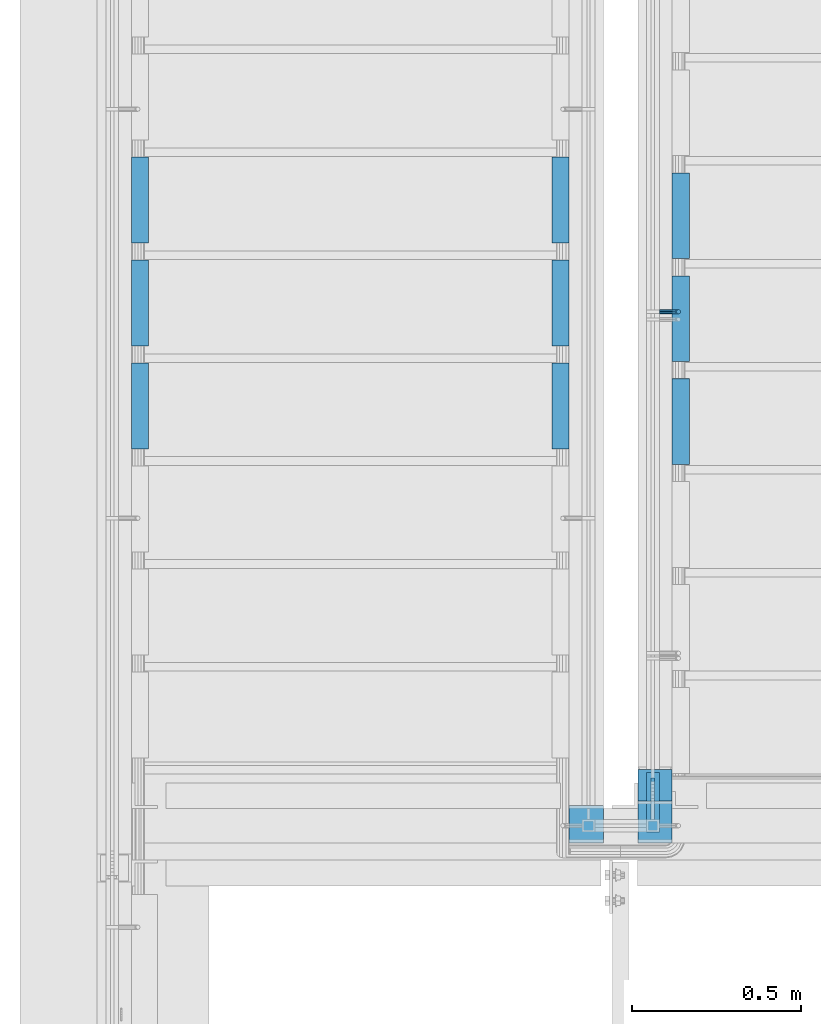
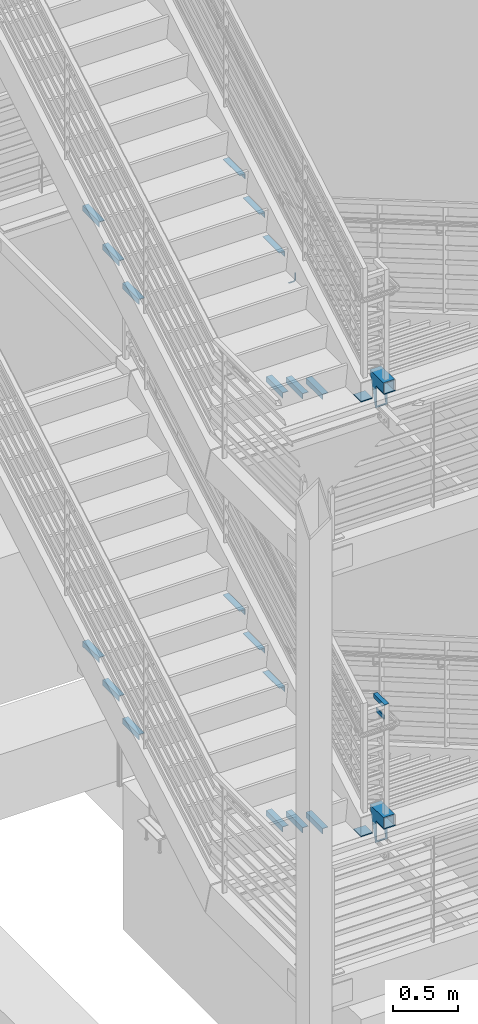
# One storey, part 860 of 1179: 26 beams, 1 member, 6 elements without a shape of their own.
"""IFC2X3 building model written with IfcOpenShell, lengths in millimetres."""

from ifc_helpers import new_model, si_unit, frame, origin_with_axes, place, context, subcontext, project, spatial, faceted_brep, material, type_object, element, aggregate, save


model = new_model("IFC2X3")

# Units and contexts
model_context = context("Model", 3, precision=1e-05, world=origin_with_axes())
body_context = subcontext(model_context, "Body", "Model", "MODEL_VIEW")
ifc_project = project(units=[si_unit("LENGTHUNIT", "METRE", prefix="MILLI"), si_unit("AREAUNIT", "SQUARE_METRE"), si_unit("VOLUMEUNIT", "CUBIC_METRE"), si_unit("MASSUNIT", "GRAM", prefix="KILO"), si_unit("TIMEUNIT", "SECOND"), si_unit("PLANEANGLEUNIT", "RADIAN"), si_unit("SOLIDANGLEUNIT", "STERADIAN"), si_unit("THERMODYNAMICTEMPERATUREUNIT", "DEGREE_CELSIUS"), si_unit("LUMINOUSINTENSITYUNIT", "LUMEN")], contexts=[model_context])

# Site, building, storey
site_placement = place(None, origin_with_axes())
site = spatial("IfcSite", under=ifc_project, at=site_placement, CompositionType="ELEMENT")
building_placement = place(site_placement, origin_with_axes())
building = spatial("IfcBuilding", under=site, at=building_placement, Name="Undefined", CompositionType="ELEMENT")
storey_placement = place(building_placement, origin_with_axes())
storey = spatial("IfcBuildingStorey", under=building, at=storey_placement, Name="Undefined", CompositionType="ELEMENT", Elevation=0.0)

# Assembly, beams
assembly_1_placement = place(storey_placement, origin_with_axes())
assembly_1 = element("IfcElementAssembly", 1, at=assembly_1_placement, inside=storey, Name="STRINGER", AssemblyPlace="NOTDEFINED", PredefinedType="RIGID_FRAME")
ifc_material_1 = material(Name="STEEL/A36")
beam_type_1 = type_object("IfcBeamType", Name="L2X2X3/16", PredefinedType="NOTDEFINED")
beam_1_placement = place(assembly_1_placement, frame((-3174.99999998141, 33462.2643783074, 7178.67500000067), z_axis=(1.0, 0.0, 0.0), x_axis=(0.0, 1.0, 0.0)))
beam_1 = element("IfcBeam", 2, at=beam_1_placement, type_object=beam_type_1, material=ifc_material_1, Name="ANGLE", ObjectType="L2X2X3/16", context=body_context, shape_type="Brep", body=[
    faceted_brep([(0.0, 25.3999999999996, -25.4000000000015), (0.0, 25.3999999999996, 25.4000000000015), (254.0, 25.3999999999996, 25.4000000000001), (254.0, 25.3999999999996, -25.4000000000001), (0.0, 20.6374999999998, 25.4000000000015), (254.0, 20.6374999999998, 25.4000000000001), (0.0, 20.6374999999998, -20.6374999999971), (254.0, 20.6374999999998, -20.6374999999998), (0.0, -25.3999999999996, -20.6374999999971), (254.0, -25.3999999999996, -20.6374999999998), (0.0, -25.3999999999996, -25.4000000000015), (254.0, -25.3999999999996, -25.4000000000001)], [[[0, 1, 2, 3]], [[1, 4, 5, 2]], [[4, 6, 7, 5]], [[6, 8, 9, 7]], [[8, 10, 11, 9]], [[10, 0, 3, 11]], [[5, 7, 9, 11, 3, 2]], [[10, 8, 6, 4, 1, 0]]]),
])
beam_2_placement = place(assembly_1_placement, frame((-1930.40000000062, 33716.2643783073, 7178.67499999954), z_axis=(-1.0, 0.0, 0.0), x_axis=(0.0, -1.0, 0.0)))
beam_2 = element("IfcBeam", 3, at=beam_2_placement, type_object=beam_type_1, material=ifc_material_1, Name="ANGLE", ObjectType="L2X2X3/16", context=body_context, shape_type="Brep", body=[
    faceted_brep([(0.0, 25.3999999999996, -25.4000000000015), (0.0, 25.3999999999996, 25.4000000000015), (254.0, 25.3999999999996, 25.4000000000001), (254.0, 25.3999999999996, -25.4000000000001), (0.0, 20.6374999999998, 25.4000000000015), (254.0, 20.6374999999998, 25.4000000000001), (0.0, 20.6374999999998, -20.6374999999971), (254.0, 20.6374999999998, -20.6374999999998), (0.0, -25.3999999999996, -20.6374999999971), (254.0, -25.3999999999996, -20.6374999999998), (0.0, -25.3999999999996, -25.4000000000015), (254.0, -25.3999999999996, -25.4000000000001)], [[[0, 1, 2, 3]], [[1, 4, 5, 2]], [[4, 6, 7, 5]], [[6, 8, 9, 7]], [[8, 10, 11, 9]], [[10, 0, 3, 11]], [[5, 7, 9, 11, 3, 2]], [[10, 8, 6, 4, 1, 0]]]),
])
beam_3_placement = place(assembly_1_placement, frame((-3174.99999998158, 33157.4643785594, 7000.87500000067), z_axis=(1.0, 0.0, 0.0), x_axis=(0.0, 1.0, 0.0)))
beam_3 = element("IfcBeam", 4, at=beam_3_placement, type_object=beam_type_1, material=ifc_material_1, Name="ANGLE", ObjectType="L2X2X3/16", context=body_context, shape_type="Brep", body=[
    faceted_brep([(0.0, 25.3999999999996, -25.4000000000015), (0.0, 25.3999999999996, 25.4000000000015), (254.0, 25.3999999999996, 25.4000000000001), (254.0, 25.3999999999996, -25.4000000000001), (0.0, 20.6374999999998, 25.4000000000015), (254.0, 20.6374999999998, 25.4000000000001), (0.0, 20.6374999999998, -20.6374999999971), (254.0, 20.6374999999998, -20.6374999999998), (0.0, -25.3999999999996, -20.6374999999971), (254.0, -25.3999999999996, -20.6374999999998), (0.0, -25.3999999999996, -25.4000000000015), (254.0, -25.3999999999996, -25.4000000000001)], [[[0, 1, 2, 3]], [[1, 4, 5, 2]], [[4, 6, 7, 5]], [[6, 8, 9, 7]], [[8, 10, 11, 9]], [[10, 0, 3, 11]], [[5, 7, 9, 11, 3, 2]], [[10, 8, 6, 4, 1, 0]]]),
])
beam_4_placement = place(assembly_1_placement, frame((-1930.40000000079, 33411.4643785594, 7000.87499999954), z_axis=(-1.0, 0.0, 0.0), x_axis=(0.0, -1.0, 0.0)))
beam_4 = element("IfcBeam", 5, at=beam_4_placement, type_object=beam_type_1, material=ifc_material_1, Name="ANGLE", ObjectType="L2X2X3/16", context=body_context, shape_type="Brep", body=[
    faceted_brep([(0.0, 25.3999999999996, -25.4000000000015), (0.0, 25.3999999999996, 25.4000000000015), (254.0, 25.3999999999996, 25.4000000000001), (254.0, 25.3999999999996, -25.4000000000001), (0.0, 20.6374999999998, 25.4000000000015), (254.0, 20.6374999999998, 25.4000000000001), (0.0, 20.6374999999998, -20.6374999999971), (254.0, 20.6374999999998, -20.6374999999998), (0.0, -25.3999999999996, -20.6374999999971), (254.0, -25.3999999999996, -20.6374999999998), (0.0, -25.3999999999996, -25.4000000000015), (254.0, -25.3999999999996, -25.4000000000001)], [[[0, 1, 2, 3]], [[1, 4, 5, 2]], [[4, 6, 7, 5]], [[6, 8, 9, 7]], [[8, 10, 11, 9]], [[10, 0, 3, 11]], [[5, 7, 9, 11, 3, 2]], [[10, 8, 6, 4, 1, 0]]]),
])
beam_5_placement = place(assembly_1_placement, frame((-3174.99999998174, 32852.6643788115, 6823.07500000067), z_axis=(1.0, 0.0, 0.0), x_axis=(0.0, 1.0, 0.0)))
beam_5 = element("IfcBeam", 6, at=beam_5_placement, type_object=beam_type_1, material=ifc_material_1, Name="ANGLE", ObjectType="L2X2X3/16", context=body_context, shape_type="Brep", body=[
    faceted_brep([(0.0, 25.3999999999996, -25.4000000000015), (0.0, 25.3999999999996, 25.4000000000015), (254.0, 25.3999999999996, 25.4000000000001), (254.0, 25.3999999999996, -25.4000000000001), (0.0, 20.6374999999998, 25.4000000000015), (254.0, 20.6374999999998, 25.4000000000001), (0.0, 20.6374999999998, -20.6374999999971), (254.0, 20.6374999999998, -20.6374999999998), (0.0, -25.3999999999996, -20.6374999999971), (254.0, -25.3999999999996, -20.6374999999998), (0.0, -25.3999999999996, -25.4000000000015), (254.0, -25.3999999999996, -25.4000000000001)], [[[0, 1, 2, 3]], [[1, 4, 5, 2]], [[4, 6, 7, 5]], [[6, 8, 9, 7]], [[8, 10, 11, 9]], [[10, 0, 3, 11]], [[5, 7, 9, 11, 3, 2]], [[10, 8, 6, 4, 1, 0]]]),
])
beam_6_placement = place(assembly_1_placement, frame((-1930.40000000095, 33106.6643788114, 6823.07499999954), z_axis=(-1.0, 0.0, 0.0), x_axis=(0.0, -1.0, 0.0)))
beam_6 = element("IfcBeam", 7, at=beam_6_placement, type_object=beam_type_1, material=ifc_material_1, Name="ANGLE", ObjectType="L2X2X3/16", context=body_context, shape_type="Brep", body=[
    faceted_brep([(0.0, 25.3999999999996, -25.4000000000015), (0.0, 25.3999999999996, 25.4000000000015), (254.0, 25.3999999999996, 25.4000000000001), (254.0, 25.3999999999996, -25.4000000000001), (0.0, 20.6374999999998, 25.4000000000015), (254.0, 20.6374999999998, 25.4000000000001), (0.0, 20.6374999999998, -20.6374999999971), (254.0, 20.6374999999998, -20.6374999999998), (0.0, -25.3999999999996, -20.6374999999971), (254.0, -25.3999999999996, -20.6374999999998), (0.0, -25.3999999999996, -25.4000000000015), (254.0, -25.3999999999996, -25.4000000000001)], [[[0, 1, 2, 3]], [[1, 4, 5, 2]], [[4, 6, 7, 5]], [[6, 8, 9, 7]], [[8, 10, 11, 9]], [[10, 0, 3, 11]], [[5, 7, 9, 11, 3, 2]], [[10, 8, 6, 4, 1, 0]]]),
])

assembly_2_placement = place(storey_placement, origin_with_axes())
assembly_2 = element("IfcElementAssembly", 8, at=assembly_2_placement, inside=storey, Name="STRINGER", AssemblyPlace="NOTDEFINED", PredefinedType="RIGID_FRAME")
beam_7_placement = place(assembly_2_placement, frame((-1574.79999999366, 32806.3356226085, 5400.67499955931), z_axis=(1.0, 0.0, 0.0), x_axis=(0.0, 1.0, 0.0)))
beam_7 = element("IfcBeam", 9, at=beam_7_placement, type_object=beam_type_1, material=ifc_material_1, Name="ANGLE", ObjectType="L2X2X3/16", context=body_context, shape_type="Brep", body=[
    faceted_brep([(0.0, 25.3999999999996, -25.4000000000015), (0.0, 25.3999999999996, 25.4000000000015), (254.0, 25.3999999999996, 25.4000000000001), (254.0, 25.3999999999996, -25.4000000000001), (0.0, 20.6374999999998, 25.4000000000015), (254.0, 20.6374999999998, 25.4000000000001), (0.0, 20.6374999999998, -20.6374999999971), (254.0, 20.6374999999998, -20.6374999999998), (0.0, -25.3999999999996, -20.6374999999971), (254.0, -25.3999999999996, -20.6374999999998), (0.0, -25.3999999999996, -25.4000000000015), (254.0, -25.3999999999996, -25.4000000000001)], [[[0, 1, 2, 3]], [[1, 4, 5, 2]], [[4, 6, 7, 5]], [[6, 8, 9, 7]], [[8, 10, 11, 9]], [[10, 0, 3, 11]], [[5, 7, 9, 11, 3, 2]], [[10, 8, 6, 4, 1, 0]]]),
])
beam_8_placement = place(assembly_2_placement, frame((-1574.79999999571, 33111.1356225445, 5222.87499944961), z_axis=(1.0, 0.0, 0.0), x_axis=(0.0, 1.0, 0.0)))
beam_8 = element("IfcBeam", 10, at=beam_8_placement, type_object=beam_type_1, material=ifc_material_1, Name="ANGLE", ObjectType="L2X2X3/16", context=body_context, shape_type="Brep", body=[
    faceted_brep([(0.0, 25.3999999999996, -25.4000000000015), (0.0, 25.3999999999996, 25.4000000000015), (254.0, 25.3999999999996, 25.4000000000001), (254.0, 25.3999999999996, -25.4000000000001), (0.0, 20.6374999999998, 25.4000000000015), (254.0, 20.6374999999998, 25.4000000000001), (0.0, 20.6374999999998, -20.6374999999971), (254.0, 20.6374999999998, -20.6374999999998), (0.0, -25.3999999999996, -20.6374999999971), (254.0, -25.3999999999996, -20.6374999999998), (0.0, -25.3999999999996, -25.4000000000015), (254.0, -25.3999999999996, -25.4000000000001)], [[[0, 1, 2, 3]], [[1, 4, 5, 2]], [[4, 6, 7, 5]], [[6, 8, 9, 7]], [[8, 10, 11, 9]], [[10, 0, 3, 11]], [[5, 7, 9, 11, 3, 2]], [[10, 8, 6, 4, 1, 0]]]),
])
beam_9_placement = place(assembly_2_placement, frame((-1574.79999999777, 33415.9356224805, 5045.07499933991), z_axis=(1.0, 0.0, 0.0), x_axis=(0.0, 1.0, 0.0)))
beam_9 = element("IfcBeam", 11, at=beam_9_placement, type_object=beam_type_1, material=ifc_material_1, Name="ANGLE", ObjectType="L2X2X3/16", context=body_context, shape_type="Brep", body=[
    faceted_brep([(0.0, 25.3999999999996, -25.4000000000015), (0.0, 25.3999999999996, 25.4000000000015), (254.0, 25.3999999999996, 25.4000000000001), (254.0, 25.3999999999996, -25.4000000000001), (0.0, 20.6374999999998, 25.4000000000015), (254.0, 20.6374999999998, 25.4000000000001), (0.0, 20.6374999999998, -20.6374999999971), (254.0, 20.6374999999998, -20.6374999999998), (0.0, -25.3999999999996, -20.6374999999971), (254.0, -25.3999999999996, -20.6374999999998), (0.0, -25.3999999999996, -25.4000000000015), (254.0, -25.3999999999996, -25.4000000000001)], [[[0, 1, 2, 3]], [[1, 4, 5, 2]], [[4, 6, 7, 5]], [[6, 8, 9, 7]], [[8, 10, 11, 9]], [[10, 0, 3, 11]], [[5, 7, 9, 11, 3, 2]], [[10, 8, 6, 4, 1, 0]]]),
])

assembly_3_placement = place(storey_placement, origin_with_axes())
assembly_3 = element("IfcElementAssembly", 12, at=assembly_3_placement, inside=storey, Name="STRINGER", AssemblyPlace="NOTDEFINED", PredefinedType="RIGID_FRAME")
beam_10_placement = place(assembly_3_placement, frame((-1574.79999997962, 32806.2814779887, 1332.47534229077), z_axis=(1.0, 0.0, 0.0), x_axis=(0.0, 1.0, 0.0)))
beam_10 = element("IfcBeam", 13, at=beam_10_placement, type_object=beam_type_1, material=ifc_material_1, Name="ANGLE", ObjectType="L2X2X3/16", context=body_context, shape_type="Brep", body=[
    faceted_brep([(0.0, 25.3999999999996, -25.4000000000015), (0.0, 25.3999999999996, 25.4000000000015), (254.0, 25.3999999999996, 25.4000000000001), (254.0, 25.3999999999996, -25.4000000000001), (0.0, 20.6374999999998, 25.4000000000015), (254.0, 20.6374999999998, 25.4000000000001), (0.0, 20.6374999999998, -20.6374999999971), (254.0, 20.6374999999998, -20.6374999999998), (0.0, -25.3999999999996, -20.6374999999971), (254.0, -25.3999999999996, -20.6374999999998), (0.0, -25.3999999999996, -25.4000000000015), (254.0, -25.3999999999996, -25.4000000000001)], [[[0, 1, 2, 3]], [[1, 4, 5, 2]], [[4, 6, 7, 5]], [[6, 8, 9, 7]], [[8, 10, 11, 9]], [[10, 0, 3, 11]], [[5, 7, 9, 11, 3, 2]], [[10, 8, 6, 4, 1, 0]]]),
])
beam_11_placement = place(assembly_3_placement, frame((-1574.79999997958, 33111.0816317228, 1155.99344815363), z_axis=(1.0, 0.0, 0.0), x_axis=(0.0, 1.0, 0.0)))
beam_11 = element("IfcBeam", 14, at=beam_11_placement, type_object=beam_type_1, material=ifc_material_1, Name="ANGLE", ObjectType="L2X2X3/16", context=body_context, shape_type="Brep", body=[
    faceted_brep([(0.0, 25.3999999999996, -25.4000000000015), (0.0, 25.3999999999996, 25.4000000000015), (254.0, 25.3999999999996, 25.4000000000001), (254.0, 25.3999999999996, -25.4000000000001), (0.0, 20.6374999999998, 25.4000000000015), (254.0, 20.6374999999998, 25.4000000000001), (0.0, 20.6374999999998, -20.6374999999971), (254.0, 20.6374999999998, -20.6374999999998), (0.0, -25.3999999999996, -20.6374999999971), (254.0, -25.3999999999996, -20.6374999999998), (0.0, -25.3999999999996, -25.4000000000015), (254.0, -25.3999999999996, -25.4000000000001)], [[[0, 1, 2, 3]], [[1, 4, 5, 2]], [[4, 6, 7, 5]], [[6, 8, 9, 7]], [[8, 10, 11, 9]], [[10, 0, 3, 11]], [[5, 7, 9, 11, 3, 2]], [[10, 8, 6, 4, 1, 0]]]),
])
beam_12_placement = place(assembly_3_placement, frame((-1574.79999997954, 33415.8817854569, 979.511554016487), z_axis=(1.0, 0.0, 0.0), x_axis=(0.0, 1.0, 0.0)))
beam_12 = element("IfcBeam", 15, at=beam_12_placement, type_object=beam_type_1, material=ifc_material_1, Name="ANGLE", ObjectType="L2X2X3/16", context=body_context, shape_type="Brep", body=[
    faceted_brep([(0.0, 25.3999999999996, -25.4000000000015), (0.0, 25.3999999999996, 25.4000000000015), (254.0, 25.3999999999996, 25.4000000000001), (254.0, 25.3999999999996, -25.4000000000001), (0.0, 20.6374999999998, 25.4000000000015), (254.0, 20.6374999999998, 25.4000000000001), (0.0, 20.6374999999998, -20.6374999999971), (254.0, 20.6374999999998, -20.6374999999998), (0.0, -25.3999999999996, -20.6374999999971), (254.0, -25.3999999999996, -20.6374999999998), (0.0, -25.3999999999996, -25.4000000000015), (254.0, -25.3999999999996, -25.4000000000001)], [[[0, 1, 2, 3]], [[1, 4, 5, 2]], [[4, 6, 7, 5]], [[6, 8, 9, 7]], [[8, 10, 11, 9]], [[10, 0, 3, 11]], [[5, 7, 9, 11, 3, 2]], [[10, 8, 6, 4, 1, 0]]]),
])

assembly_4_placement = place(storey_placement, origin_with_axes())
assembly_4 = element("IfcElementAssembly", 16, at=assembly_4_placement, inside=storey, Name="STRINGER", AssemblyPlace="NOTDEFINED", PredefinedType="RIGID_FRAME")
beam_13_placement = place(assembly_4_placement, frame((-3175.00000000384, 33462.3192616817, 3097.21250000058), z_axis=(1.0, 0.0, 0.0), x_axis=(0.0, 1.0, 0.0)))
beam_13 = element("IfcBeam", 17, at=beam_13_placement, type_object=beam_type_1, material=ifc_material_1, Name="ANGLE", ObjectType="L2X2X3/16", context=body_context, shape_type="Brep", body=[
    faceted_brep([(0.0, 25.3999999999996, -25.4000000000015), (0.0, 25.3999999999996, 25.4000000000015), (254.0, 25.3999999999996, 25.4000000000001), (254.0, 25.3999999999996, -25.4000000000001), (0.0, 20.6374999999998, 25.4000000000015), (254.0, 20.6374999999998, 25.4000000000001), (0.0, 20.6374999999998, -20.6374999999971), (254.0, 20.6374999999998, -20.6374999999998), (0.0, -25.3999999999996, -20.6374999999971), (254.0, -25.3999999999996, -20.6374999999998), (0.0, -25.3999999999996, -25.4000000000015), (254.0, -25.3999999999996, -25.4000000000001)], [[[0, 1, 2, 3]], [[1, 4, 5, 2]], [[4, 6, 7, 5]], [[6, 8, 9, 7]], [[8, 10, 11, 9]], [[10, 0, 3, 11]], [[5, 7, 9, 11, 3, 2]], [[10, 8, 6, 4, 1, 0]]]),
])
beam_14_placement = place(assembly_4_placement, frame((-1930.40000000084, 33716.3192616817, 3097.21250000058), z_axis=(-1.0, 0.0, 0.0), x_axis=(0.0, -1.0, 0.0)))
beam_14 = element("IfcBeam", 18, at=beam_14_placement, type_object=beam_type_1, material=ifc_material_1, Name="ANGLE", ObjectType="L2X2X3/16", context=body_context, shape_type="Brep", body=[
    faceted_brep([(0.0, 25.3999999999996, -25.4000000000015), (0.0, 25.3999999999996, 25.4000000000015), (254.0, 25.3999999999996, 25.4000000000001), (254.0, 25.3999999999996, -25.4000000000001), (0.0, 20.6374999999998, 25.4000000000015), (254.0, 20.6374999999998, 25.4000000000001), (0.0, 20.6374999999998, -20.6374999999971), (254.0, 20.6374999999998, -20.6374999999998), (0.0, -25.3999999999996, -20.6374999999971), (254.0, -25.3999999999996, -20.6374999999998), (0.0, -25.3999999999996, -25.4000000000015), (254.0, -25.3999999999996, -25.4000000000001)], [[[0, 1, 2, 3]], [[1, 4, 5, 2]], [[4, 6, 7, 5]], [[6, 8, 9, 7]], [[8, 10, 11, 9]], [[10, 0, 3, 11]], [[5, 7, 9, 11, 3, 2]], [[10, 8, 6, 4, 1, 0]]]),
])
beam_15_placement = place(assembly_4_placement, frame((-3175.00000000384, 33157.519261771, 2920.73541666725), z_axis=(1.0, 0.0, 0.0), x_axis=(0.0, 1.0, 0.0)))
beam_15 = element("IfcBeam", 19, at=beam_15_placement, type_object=beam_type_1, material=ifc_material_1, Name="ANGLE", ObjectType="L2X2X3/16", context=body_context, shape_type="Brep", body=[
    faceted_brep([(0.0, 25.3999999999996, -25.4000000000015), (0.0, 25.3999999999996, 25.4000000000015), (254.0, 25.3999999999996, 25.4000000000001), (254.0, 25.3999999999996, -25.4000000000001), (0.0, 20.6374999999998, 25.4000000000015), (254.0, 20.6374999999998, 25.4000000000001), (0.0, 20.6374999999998, -20.6374999999971), (254.0, 20.6374999999998, -20.6374999999998), (0.0, -25.3999999999996, -20.6374999999971), (254.0, -25.3999999999996, -20.6374999999998), (0.0, -25.3999999999996, -25.4000000000015), (254.0, -25.3999999999996, -25.4000000000001)], [[[0, 1, 2, 3]], [[1, 4, 5, 2]], [[4, 6, 7, 5]], [[6, 8, 9, 7]], [[8, 10, 11, 9]], [[10, 0, 3, 11]], [[5, 7, 9, 11, 3, 2]], [[10, 8, 6, 4, 1, 0]]]),
])
beam_16_placement = place(assembly_4_placement, frame((-1930.40000000084, 33411.519261771, 2920.73541666725), z_axis=(-1.0, 0.0, 0.0), x_axis=(0.0, -1.0, 0.0)))
beam_16 = element("IfcBeam", 20, at=beam_16_placement, type_object=beam_type_1, material=ifc_material_1, Name="ANGLE", ObjectType="L2X2X3/16", context=body_context, shape_type="Brep", body=[
    faceted_brep([(0.0, 25.3999999999996, -25.4000000000015), (0.0, 25.3999999999996, 25.4000000000015), (254.0, 25.3999999999996, 25.4000000000001), (254.0, 25.3999999999996, -25.4000000000001), (0.0, 20.6374999999998, 25.4000000000015), (254.0, 20.6374999999998, 25.4000000000001), (0.0, 20.6374999999998, -20.6374999999971), (254.0, 20.6374999999998, -20.6374999999998), (0.0, -25.3999999999996, -20.6374999999971), (254.0, -25.3999999999996, -20.6374999999998), (0.0, -25.3999999999996, -25.4000000000015), (254.0, -25.3999999999996, -25.4000000000001)], [[[0, 1, 2, 3]], [[1, 4, 5, 2]], [[4, 6, 7, 5]], [[6, 8, 9, 7]], [[8, 10, 11, 9]], [[10, 0, 3, 11]], [[5, 7, 9, 11, 3, 2]], [[10, 8, 6, 4, 1, 0]]]),
])
beam_17_placement = place(assembly_4_placement, frame((-3175.00000000384, 32852.7192618602, 2744.25833333391), z_axis=(1.0, 0.0, 0.0), x_axis=(0.0, 1.0, 0.0)))
beam_17 = element("IfcBeam", 21, at=beam_17_placement, type_object=beam_type_1, material=ifc_material_1, Name="ANGLE", ObjectType="L2X2X3/16", context=body_context, shape_type="Brep", body=[
    faceted_brep([(0.0, 25.3999999999996, -25.4000000000015), (0.0, 25.3999999999996, 25.4000000000015), (254.0, 25.3999999999996, 25.4000000000001), (254.0, 25.3999999999996, -25.4000000000001), (0.0, 20.6374999999998, 25.4000000000015), (254.0, 20.6374999999998, 25.4000000000001), (0.0, 20.6374999999998, -20.6374999999971), (254.0, 20.6374999999998, -20.6374999999998), (0.0, -25.3999999999996, -20.6374999999971), (254.0, -25.3999999999996, -20.6374999999998), (0.0, -25.3999999999996, -25.4000000000015), (254.0, -25.3999999999996, -25.4000000000001)], [[[0, 1, 2, 3]], [[1, 4, 5, 2]], [[4, 6, 7, 5]], [[6, 8, 9, 7]], [[8, 10, 11, 9]], [[10, 0, 3, 11]], [[5, 7, 9, 11, 3, 2]], [[10, 8, 6, 4, 1, 0]]]),
])
beam_18_placement = place(assembly_4_placement, frame((-1930.40000000084, 33106.7192618602, 2744.25833333391), z_axis=(-1.0, 0.0, 0.0), x_axis=(0.0, -1.0, 0.0)))
beam_18 = element("IfcBeam", 22, at=beam_18_placement, type_object=beam_type_1, material=ifc_material_1, Name="ANGLE", ObjectType="L2X2X3/16", context=body_context, shape_type="Brep", body=[
    faceted_brep([(0.0, 25.3999999999996, -25.4000000000015), (0.0, 25.3999999999996, 25.4000000000015), (254.0, 25.3999999999996, 25.4000000000001), (254.0, 25.3999999999996, -25.4000000000001), (0.0, 20.6374999999998, 25.4000000000015), (254.0, 20.6374999999998, 25.4000000000001), (0.0, 20.6374999999998, -20.6374999999971), (254.0, 20.6374999999998, -20.6374999999998), (0.0, -25.3999999999996, -20.6374999999971), (254.0, -25.3999999999996, -20.6374999999998), (0.0, -25.3999999999996, -25.4000000000015), (254.0, -25.3999999999996, -25.4000000000001)], [[[0, 1, 2, 3]], [[1, 4, 5, 2]], [[4, 6, 7, 5]], [[6, 8, 9, 7]], [[8, 10, 11, 9]], [[10, 0, 3, 11]], [[5, 7, 9, 11, 3, 2]], [[10, 8, 6, 4, 1, 0]]]),
])

# Assembly, beam
assembly_5_placement = place(storey_placement, origin_with_axes())
assembly_5 = element("IfcElementAssembly", 23, at=assembly_5_placement, inside=storey, Name="GUARDRAIL", AssemblyPlace="NOTDEFINED", PredefinedType="RIGID_FRAME")
beam_type_2 = type_object("IfcBeamType", PredefinedType="NOTDEFINED")
beam_19_placement = place(assembly_5_placement, frame((-1638.3000007445, 33258.7593248028, 6208.77780559142), z_axis=(0.0, 0.0, 1.0), x_axis=(1.0, 0.0, 0.0)))
beam_19 = element("IfcBeam", 24, at=beam_19_placement, type_object=beam_type_2, material=ifc_material_1, Name="BRACKET", context=body_context, shape_type="Brep", body=[
    faceted_brep([(0.0, -4.49012806053361, 4.49012806053452), (0.0, 0.0, 6.34999999999991), (0.0, 4.49012806053361, 4.49012806053452), (0.0, 6.34999999999854, 0.0), (0.0, 4.49012806053361, -4.49012806053452), (0.0, 0.0, -6.34999999999991), (0.0, -4.49012806053361, -4.49012806053452), (0.0, -6.34999999999854, 0.0), (44.4500031699827, 0.0, -6.34999999999991), (44.4500031699827, -4.49012806053361, -4.49012806053452), (44.4500031699827, -6.34999999999854, 2.19733919948339e-09), (44.4500031699827, -4.49012806053361, 4.49012806053452), (44.4500031699827, 0.0, 6.34999999999991), (44.4500031699827, 4.49012806053361, 4.49012806053452), (44.4500031699827, 6.34999999999854, 0.0), (44.4500031699827, 4.49012806053361, -4.49012806053452), (53.0450671075391, 4.4901280570557, -2.18708762112465), (53.97500307462, -4.32919478043914e-09, -3.79778396764459), (53.0450671022344, -4.49012806401151, -2.1870876194389), (50.8000030708674, -6.35000000142099, 1.70147734757802), (48.5549390416977, -4.4901280599006, 5.59004231389645), (47.6250030746168, 1.48793333210051e-09, 7.20073866041594), (48.5549390470023, 4.49012806117025, 5.5900423122107), (50.8000030783693, 6.34999999857973, 1.70147734519378), (55.4485256393576, 6.34999999469437, 6.34999990618098), (59.337090604122, 4.49012805180246, 4.10493587545716), (51.5599606707875, 4.49012805866005, 8.59506393599531), (49.9492643188311, -4.54747350886464e-10, 9.52499990463002), (51.5599606615996, -4.4901280624108, 8.59506393379797), (55.4485256263639, -6.35000000530636, 6.34999990307369), (59.337090594938, -4.49012806926839, 4.10493587326664), (60.9477869468905, -1.0153598850593e-08, 3.17499990462466), (61.6401310450869, 4.49012804462109, 12.6999998130159), (63.5000029792477, -1.81098585017025e-08, 12.6999998092651), (57.1500029867496, 6.3499999893902, 12.6999998145698), (52.6598749240178, 4.49012805522943, 12.6999998130159), (50.8000029792477, -3.10683390125632e-09, 12.6999998092651), (52.6598749134085, -4.49012806583778, 12.6999998055144), (57.1500029739432, -6.35000001061053, 12.6999998039605), (61.6401310344776, -4.49012807644976, 12.6999998055144), (63.5000029792478, -6.94672053214163e-08, 76.1999999999989), (61.6401296126726, -4.49012700530147, 78.8192413787656), (57.1500015702525, -6.34999899300601, 79.9041667058245), (52.6598734916033, -4.49012712912372, 78.8192414509958), (50.8000029792478, -5.78438630327582e-08, 76.1999999999989), (52.6598733663452, 4.49012892448809, 73.5807587487216), (57.1500014002204, 6.35000091363327, 72.4958334208259), (61.6401294874142, 4.49012905118434, 73.580758674816)], [[[0, 1, 2, 3, 4, 5, 6, 7]], [[6, 5, 8, 9]], [[7, 6, 9, 10]], [[0, 7, 10, 11]], [[1, 0, 11, 12]], [[2, 1, 12, 13]], [[3, 2, 13, 14]], [[4, 3, 14, 15]], [[5, 4, 15, 8]], [[8, 15, 16, 17]], [[9, 8, 17, 18]], [[10, 9, 18, 19]], [[11, 10, 19, 20]], [[12, 11, 20, 21]], [[13, 12, 21, 22]], [[14, 13, 22, 23]], [[15, 14, 23, 16]], [[23, 24, 25, 16]], [[22, 26, 24, 23]], [[21, 27, 26, 22]], [[20, 28, 27, 21]], [[19, 29, 28, 20]], [[18, 30, 29, 19]], [[17, 31, 30, 18]], [[16, 25, 31, 17]], [[25, 32, 33, 31]], [[24, 34, 32, 25]], [[26, 35, 34, 24]], [[27, 36, 35, 26]], [[28, 37, 36, 27]], [[29, 38, 37, 28]], [[30, 39, 38, 29]], [[31, 33, 39, 30]], [[39, 33, 40, 41]], [[38, 39, 41, 42]], [[37, 38, 42, 43]], [[36, 37, 43, 44]], [[35, 36, 44, 45]], [[34, 35, 45, 46]], [[32, 34, 46, 47]], [[33, 32, 47, 40]], [[46, 45, 44, 43, 42, 41, 40, 47]]]),
])
aggregate(assembly_5, [beam_19])

# Beam
beam_type_3 = type_object("IfcBeamType", PredefinedType="NOTDEFINED")
beam_20_placement = place(assembly_2_placement, frame((-1651.0, 31686.4999999887, 6142.03749999882), z_axis=(-1.0, 0.0, 0.0), x_axis=(0.0, 1.0, 0.0)))
beam_20 = element("IfcBeam", 25, at=beam_20_placement, type_object=beam_type_3, material=ifc_material_1, Name="PLATE", context=body_context, shape_type="Brep", body=[
    faceted_brep([(0.0, 4.76249999999982, -50.7999999999993), (0.0, 4.76249999999982, 50.7999999999993), (123.824999996345, 4.76249999999982, 50.8), (123.824999996345, 4.76249999999982, -50.8), (0.0, -4.76249999999982, 50.7999999999993), (123.824999996345, -4.76249999999982, 50.8), (0.0, -4.76249999999982, -50.7999999999993), (123.824999996345, -4.76249999999982, -50.8)], [[[0, 1, 2, 3]], [[1, 4, 5, 2]], [[4, 6, 7, 5]], [[6, 0, 3, 7]], [[5, 7, 3, 2]], [[6, 4, 1, 0]]]),
])

beam_21_placement = place(assembly_1_placement, frame((-1854.20000000477, 31686.499999989, 6142.03749999882), z_axis=(-1.0, 0.0, 0.0), x_axis=(0.0, 1.0, 0.0)))
beam_21 = element("IfcBeam", 26, at=beam_21_placement, type_object=beam_type_3, material=ifc_material_1, Name="PLATE", context=body_context, shape_type="Brep", body=[
    faceted_brep([(0.0, 4.76249999999982, -50.7999999999993), (0.0, 4.76249999999982, 50.7999999999993), (111.125000010961, 4.76249999999982, 50.8), (111.125000010961, 4.76249999999982, -50.8), (0.0, -4.76249999999982, 50.7999999999993), (111.125000010961, -4.76249999999982, 50.8), (0.0, -4.76249999999982, -50.7999999999993), (111.125000010961, -4.76249999999982, -50.8)], [[[0, 1, 2, 3]], [[1, 4, 5, 2]], [[4, 6, 7, 5]], [[6, 0, 3, 7]], [[5, 7, 3, 2]], [[6, 4, 1, 0]]]),
])

aggregate(assembly_1, [beam_1, beam_2, beam_3, beam_4, beam_5, beam_6, beam_21])

beam_22_placement = place(assembly_4_placement, frame((-1854.20000000477, 31686.499999989, 2068.5125000003), z_axis=(-1.0, 0.0, 0.0), x_axis=(0.0, 1.0, 0.0)))
beam_22 = element("IfcBeam", 27, at=beam_22_placement, type_object=beam_type_3, material=ifc_material_1, Name="PLATE", context=body_context, shape_type="Brep", body=[
    faceted_brep([(0.0, 4.76249999999982, -50.7999999999993), (0.0, 4.76249999999982, 50.7999999999993), (111.125000010961, 4.76249999999982, 50.8), (111.125000010961, 4.76249999999982, -50.8), (0.0, -4.76249999999982, 50.7999999999993), (111.125000010961, -4.76249999999982, 50.8), (0.0, -4.76249999999982, -50.7999999999993), (111.125000010961, -4.76249999999982, -50.8)], [[[0, 1, 2, 3]], [[1, 4, 5, 2]], [[4, 6, 7, 5]], [[6, 0, 3, 7]], [[5, 7, 3, 2]], [[6, 4, 1, 0]]]),
])

aggregate(assembly_4, [beam_13, beam_14, beam_15, beam_16, beam_17, beam_18, beam_22])

beam_23_placement = place(assembly_3_placement, frame((-1651.00000000632, 31686.4999999887, 2068.5125000003), z_axis=(-1.0, 0.0, 0.0), x_axis=(0.0, 1.0, 0.0)))
beam_23 = element("IfcBeam", 28, at=beam_23_placement, type_object=beam_type_3, material=ifc_material_1, Name="PLATE", context=body_context, shape_type="Brep", body=[
    faceted_brep([(0.0, 4.76249999999982, -50.7999999999993), (0.0, 4.76249999999982, 50.7999999999993), (123.824999996345, 4.76249999999982, 50.8), (123.824999996345, 4.76249999999982, -50.8), (0.0, -4.76249999999982, 50.7999999999993), (123.824999996345, -4.76249999999982, 50.8), (0.0, -4.76249999999982, -50.7999999999993), (123.824999996345, -4.76249999999982, -50.8)], [[[0, 1, 2, 3]], [[1, 4, 5, 2]], [[4, 6, 7, 5]], [[6, 0, 3, 7]], [[5, 7, 3, 2]], [[6, 4, 1, 0]]]),
])

# Assembly, beam, member
assembly_6_placement = place(storey_placement, origin_with_axes())
assembly_6 = element("IfcElementAssembly", 29, at=assembly_6_placement, inside=storey, Name="GUARDRAIL", AssemblyPlace="NOTDEFINED", PredefinedType="RIGID_FRAME")
beam_type_4 = type_object("IfcBeamType", PredefinedType="NOTDEFINED")
beam_24_placement = place(assembly_6_placement, frame((-1657.3499991948, 31879.4657549711, 3057.57791887665), z_axis=(0.0, 0.0, 1.0), x_axis=(0.0, -1.0, 0.0)))
beam_24 = element("IfcBeam", 30, at=beam_24_placement, type_object=beam_type_4, material=ifc_material_1, Name="PLATE", context=body_context, shape_type="Brep", body=[
    faceted_brep([(10.6006355317113, 4.76250000000005, -19.0500000000002), (0.366391600862698, 4.76250000000005, 19.0500000000002), (123.114215693655, 4.76250000000005, 19.0500000000002), (123.114280311253, 4.76250000000005, -19.0500000000002), (0.366391600862698, -4.76250000000005, 19.0500000000002), (123.114215693655, -4.76250000000005, 19.0500000000002), (10.6006355317113, -4.76250000000005, -19.0500000000002), (123.114280311253, -4.76250000000005, -19.0500000000002)], [[[0, 1, 2, 3]], [[1, 4, 5, 2]], [[4, 6, 7, 5]], [[6, 0, 3, 7]], [[5, 7, 3, 2]], [[6, 4, 1, 0]]]),
])
ifc_material_2 = material()
member_type = type_object("IfcMemberType", Name="HSS1-1/2X1-1/2X1/4", PredefinedType="NOTDEFINED")
member_placement = place(assembly_6_placement, frame((-1657.34999921452, 31884.5828805815, 3184.5779465882), z_axis=(0.0, 0.0, 1.0), x_axis=(0.0, -1.0, 0.0)))
member = element("IfcMember", 31, at=member_placement, type_object=member_type, material=ifc_material_2, Name="GUARDRAIL", ObjectType="HSS1-1/2X1-1/2X1/4", context=body_context, shape_type="Brep", body=[
    faceted_brep([(-1.70114958583872, 12.6999993300001, -12.6999993300001), (-1.70114958583872, -12.6999993300001, -12.6999993300001), (134.58118720464, -12.6999993300001, -12.6999993299487), (134.58118720464, 12.6999993300001, -12.6999993299487), (-8.53298734107739, -12.6999993300001, 12.6999993300001), (159.981135257905, -12.6999993300001, 12.6999993299983), (-8.53298734107739, 12.6999993300001, 12.6999993300001), (159.981135257905, 12.6999993300001, 12.6999993299983), (0.00683940290036844, 19.0499992350001, -19.0499992350005), (-10.2409468444384, 19.0499992350001, 19.0499992350001), (166.331124399308, 19.0499992350001, 19.0499992349987), (128.231187255638, 19.0499992350001, -19.0499992349514), (-10.2409468444384, -19.0499992350001, 19.0499992350001), (166.331124399308, -19.0499992350001, 19.0499992349987), (0.00683940290036844, -19.0499992350001, -19.0499992350005), (128.231187255638, -19.0499992350001, -19.0499992349514)], [[[0, 1, 2, 3]], [[1, 4, 5, 2]], [[4, 6, 7, 5]], [[6, 0, 3, 7]], [[8, 9, 10, 11]], [[9, 12, 13, 10]], [[12, 14, 15, 13]], [[14, 8, 11, 15]], [[13, 15, 11, 10], [5, 7, 3, 2]], [[14, 12, 9, 8], [6, 4, 1, 0]]]),
])
aggregate(assembly_6, [beam_24, member])

# Beam
beam_type_5 = type_object("IfcBeamType", Name="HSS12X4X3/8", PredefinedType="NOTDEFINED")
beam_25_placement = place(assembly_2_placement, frame((-1650.99999997088, 31903.4337363971, 6089.64999999951), z_axis=(0.0, 0.0, 1.0), x_axis=(0.0, -1.0, 0.0)))
beam_25 = element("IfcBeam", 32, at=beam_25_placement, type_object=beam_type_5, material=ifc_material_2, Name="STRINGER", ObjectType="HSS12X4X3/8", context=body_context, shape_type="Brep", body=[
    faceted_brep([(93.108736390408, 41.2750000000001, 57.1500000007454), (93.108736390408, 50.8, 57.1500000007454), (207.408736386758, 50.8, 57.1499999999924), (207.408736386758, 41.2750000000001, 57.1499999999924), (93.1087363904007, -50.8, -152.4), (93.1087363904007, 50.8, -152.4), (93.1087363904007, 41.2750000000001, -142.875), (93.1087363904007, -41.2750000000001, -142.875), (93.108736390408, -41.2750000000001, 57.1500000007454), (93.108736390408, -50.8, 57.1500000007454), (207.408736386758, -41.2750000000001, 57.1499999999924), (207.408736386758, -50.8, 57.1499999999924), (207.408736408361, -50.8, 152.452918827234), (207.408736386758, -41.2750000000001, 142.875), (207.408736386758, 41.2750000000001, 142.875), (207.408736386758, 50.8, 152.4), (0.10500632079129, 50.8, 152.4), (0.10500632079129, -50.8, 152.4), (82.402418237336, -50.8000000000029, -152.4), (82.402418237336, 50.8000000000029, -152.4), (2.67680044796725, 41.2750000000001, 142.875), (2.67680044796725, -41.2750000000001, 142.875), (79.8306242632716, -41.2750000000001, -142.875), (79.8306242632716, 41.2750000000001, -142.875)], [[[0, 1, 2, 3]], [[4, 5, 1, 0, 6, 7, 8, 9]], [[9, 8, 10, 11]], [[12, 11, 10, 13, 14, 3, 2, 15]], [[16, 17, 12, 15]], [[18, 19, 5, 4]], [[17, 18, 4, 9, 11, 12]], [[1, 5, 19, 16, 15, 2]], [[18, 17, 16, 19], [20, 21, 22, 23]], [[8, 7, 22, 21, 13, 10]], [[23, 22, 7, 6]], [[20, 23, 6, 0, 3, 14]], [[21, 20, 14, 13]]]),
])

aggregate(assembly_2, [beam_7, beam_8, beam_9, beam_20, beam_25])

beam_26_placement = place(assembly_3_placement, frame((-1650.99999997901, 31903.3456585728, 2016.17791884077), z_axis=(0.0, 0.0, 1.0), x_axis=(0.0, -1.0, 0.0)))
beam_26 = element("IfcBeam", 33, at=beam_26_placement, type_object=beam_type_5, material=ifc_material_2, Name="STRINGER", ObjectType="HSS12X4X3/8", context=body_context, shape_type="Brep", body=[
    faceted_brep([(93.0206585727828, 41.2750000000001, 57.0970811595257), (93.0206585727828, 50.8, 57.0970811595257), (207.320658584067, 50.8, 57.0970811595257), (207.320658584067, 41.2750000000001, 57.0970811595257), (93.0206585727828, -50.8, -152.4), (93.0206585727828, 50.8, -152.4), (93.0206585727828, 41.2750000000001, -142.875), (93.0206585727828, -41.2750000000001, -142.875), (93.0206585727828, -41.2750000000001, 57.0970811595257), (93.0206585727828, -50.8, 57.0970811595257), (207.320658584067, -41.2750000000001, 57.0970811595257), (207.320658584067, -50.8, 57.0970811595257), (207.320658584067, -50.8, 152.399999987435), (207.320658584067, -41.2750000000001, 142.875), (207.320658584067, 41.2750000000001, 142.875), (207.320658584067, 50.8, 152.4), (0.0, 50.8000000000029, 152.4), (0.0, -50.8000000000029, 152.4), (81.8739509559236, -50.8, -152.4), (81.8739509559236, 50.8, -152.4), (2.5585604918524, 41.2750000000001, 142.875), (2.5585604918524, -41.2750000000001, 142.875), (79.3153899732097, -41.2750000000001, -142.875), (79.3153899732097, 41.2750000000001, -142.875)], [[[0, 1, 2, 3]], [[4, 5, 1, 0, 6, 7, 8, 9]], [[9, 8, 10, 11]], [[12, 11, 10, 13, 14, 3, 2, 15]], [[16, 17, 12, 15]], [[18, 19, 5, 4]], [[17, 18, 4, 9, 11, 12]], [[1, 5, 19, 16, 15, 2]], [[18, 17, 16, 19], [20, 21, 22, 23]], [[8, 7, 22, 21, 13, 10]], [[23, 22, 7, 6]], [[20, 23, 6, 0, 3, 14]], [[21, 20, 14, 13]]]),
])

aggregate(assembly_3, [beam_10, beam_11, beam_12, beam_23, beam_26])

save(model, "model.ifc")
